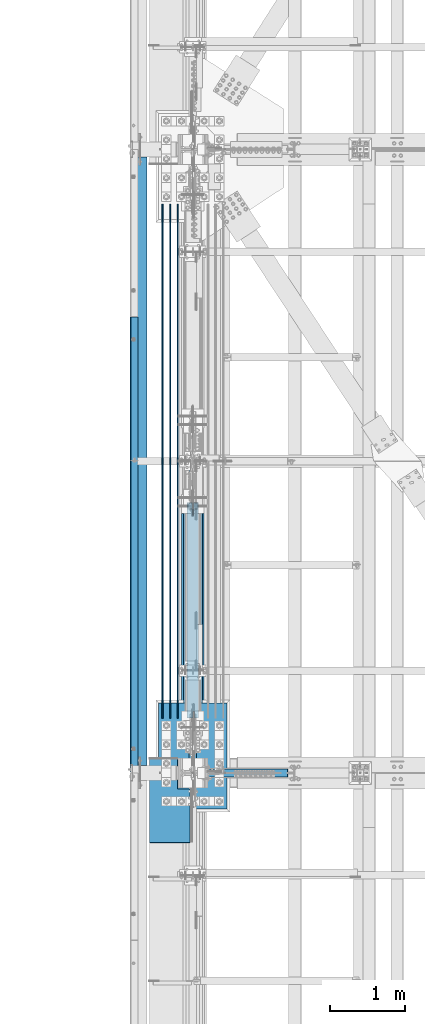
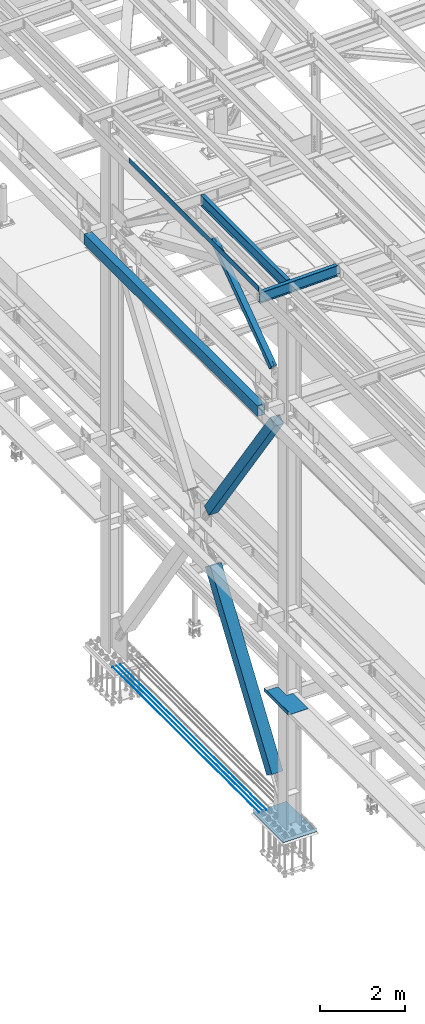
# One storey, part 1867 of 3843: 9 beams, 3 members, 12 elements without a shape of their own.
"""IFC2X3 building model written with IfcOpenShell, lengths in millimetres."""

from ifc_helpers import new_model, si_unit, frame, origin_with_axes, place, context, subcontext, project, spatial, faceted_brep, material, type_object, element, aggregate, save


model = new_model("IFC2X3")

# Units and contexts
model_context = context("Model", 3, precision=1e-05, world=origin_with_axes())
body_context = subcontext(model_context, "Body", "Model", "MODEL_VIEW")
ifc_project = project(units=[si_unit("LENGTHUNIT", "METRE", prefix="MILLI"), si_unit("AREAUNIT", "SQUARE_METRE"), si_unit("VOLUMEUNIT", "CUBIC_METRE"), si_unit("MASSUNIT", "GRAM", prefix="KILO"), si_unit("TIMEUNIT", "SECOND"), si_unit("PLANEANGLEUNIT", "RADIAN"), si_unit("SOLIDANGLEUNIT", "STERADIAN"), si_unit("THERMODYNAMICTEMPERATUREUNIT", "DEGREE_CELSIUS"), si_unit("LUMINOUSINTENSITYUNIT", "LUMEN")], contexts=[model_context])

# Site, building, storey
site_placement = place(None, origin_with_axes())
site = spatial("IfcSite", under=ifc_project, at=site_placement, CompositionType="ELEMENT")
building_placement = place(site_placement, origin_with_axes())
building = spatial("IfcBuilding", under=site, at=building_placement, Name="Undefined", CompositionType="ELEMENT")
storey_placement = place(building_placement, origin_with_axes())
storey = spatial("IfcBuildingStorey", under=building, at=storey_placement, Name="Undefined", CompositionType="ELEMENT", Elevation=0.0)

# Assembly, beam
assembly_1_placement = place(storey_placement, origin_with_axes())
assembly_1 = element("IfcElementAssembly", 1, at=assembly_1_placement, inside=storey, Name="REBAR", AssemblyPlace="NOTDEFINED", PredefinedType="RIGID_FRAME")
ifc_material_1 = material(Name="STEEL/A706-60")
beam_type_1 = type_object("IfcBeamType", Name="#10 REBAR", PredefinedType="NOTDEFINED")
beam_1_placement = place(assembly_1_placement, frame((36169.6000610352, 68008.5000170885, 30170.4375), z_axis=(0.0, 0.0, 1.0), x_axis=(0.0, 1.0, 0.0)))
beam_1 = element("IfcBeam", 2, at=beam_1_placement, type_object=beam_type_1, material=ifc_material_1, Name="REBAR", ObjectType="#10 REBAR", context=body_context, shape_type="Brep", body=[
    faceted_brep([(0.0, -7.9375, 0.0), (0.0, -5.61266007566883, -5.61266007566883), (6883.48749999408, -5.61266007566883, -5.61266007566883), (6883.48749999408, -7.9375, 0.0), (0.0, 0.0, -7.9375), (6883.48749999408, 0.0, -7.9375), (0.0, 5.61266007566883, -5.61266007566883), (6883.48749999408, 5.61266007566883, -5.61266007566883), (0.0, 7.9375, 0.0), (6883.48749999408, 7.9375, 0.0), (0.0, 5.61266007566883, 5.61266007566883), (6883.48749999408, 5.61266007566883, 5.61266007566883), (0.0, 0.0, 7.9375), (6883.48749999408, 0.0, 7.9375), (0.0, -5.61266007566883, 5.61266007566883), (6883.48749999408, -5.61266007566883, 5.61266007566883)], [[[0, 1, 2, 3]], [[1, 4, 5, 2]], [[4, 6, 7, 5]], [[6, 8, 9, 7]], [[8, 10, 11, 9]], [[10, 12, 13, 11]], [[12, 14, 15, 13]], [[14, 0, 3, 15]], [[5, 7, 9, 11, 13, 15, 3, 2]], [[14, 12, 10, 8, 6, 4, 1, 0]]]),
])
aggregate(assembly_1, [beam_1])

assembly_2_placement = place(storey_placement, origin_with_axes())
assembly_2 = element("IfcElementAssembly", 3, at=assembly_2_placement, inside=storey, Name="REBAR", AssemblyPlace="NOTDEFINED", PredefinedType="RIGID_FRAME")
beam_2_placement = place(assembly_2_placement, frame((36271.2000610352, 68008.5000170885, 30170.4375), z_axis=(0.0, 0.0, 1.0), x_axis=(0.0, 1.0, 0.0)))
beam_2 = element("IfcBeam", 4, at=beam_2_placement, type_object=beam_type_1, material=ifc_material_1, Name="REBAR", ObjectType="#10 REBAR", context=body_context, shape_type="Brep", body=[
    faceted_brep([(0.0, -7.9375, 0.0), (0.0, -5.61266007566883, -5.61266007566883), (6883.48749999408, -5.61266007566883, -5.61266007566883), (6883.48749999408, -7.9375, 0.0), (0.0, 0.0, -7.9375), (6883.48749999408, 0.0, -7.9375), (0.0, 5.61266007566883, -5.61266007566883), (6883.48749999408, 5.61266007566883, -5.61266007566883), (0.0, 7.9375, 0.0), (6883.48749999408, 7.9375, 0.0), (0.0, 5.61266007566883, 5.61266007566883), (6883.48749999408, 5.61266007566883, 5.61266007566883), (0.0, 0.0, 7.9375), (6883.48749999408, 0.0, 7.9375), (0.0, -5.61266007566883, 5.61266007566883), (6883.48749999408, -5.61266007566883, 5.61266007566883)], [[[0, 1, 2, 3]], [[1, 4, 5, 2]], [[4, 6, 7, 5]], [[6, 8, 9, 7]], [[8, 10, 11, 9]], [[10, 12, 13, 11]], [[12, 14, 15, 13]], [[14, 0, 3, 15]], [[5, 7, 9, 11, 13, 15, 3, 2]], [[14, 12, 10, 8, 6, 4, 1, 0]]]),
])
aggregate(assembly_2, [beam_2])

assembly_3_placement = place(storey_placement, origin_with_axes())
assembly_3 = element("IfcElementAssembly", 5, at=assembly_3_placement, inside=storey, Name="REBAR", AssemblyPlace="NOTDEFINED", PredefinedType="RIGID_FRAME")
beam_3_placement = place(assembly_3_placement, frame((36372.8000610352, 68008.5000170885, 30170.4375), z_axis=(0.0, 0.0, 1.0), x_axis=(0.0, 1.0, 0.0)))
beam_3 = element("IfcBeam", 6, at=beam_3_placement, type_object=beam_type_1, material=ifc_material_1, Name="REBAR", ObjectType="#10 REBAR", context=body_context, shape_type="Brep", body=[
    faceted_brep([(0.0, -7.9375, 0.0), (0.0, -5.61266007566883, -5.61266007566883), (6883.48749999408, -5.61266007566883, -5.61266007566883), (6883.48749999408, -7.9375, 0.0), (0.0, 0.0, -7.9375), (6883.48749999408, 0.0, -7.9375), (0.0, 5.61266007566883, -5.61266007566883), (6883.48749999408, 5.61266007566883, -5.61266007566883), (0.0, 7.9375, 0.0), (6883.48749999408, 7.9375, 0.0), (0.0, 5.61266007566883, 5.61266007566883), (6883.48749999408, 5.61266007566883, 5.61266007566883), (0.0, 0.0, 7.9375), (6883.48749999408, 0.0, 7.9375), (0.0, -5.61266007566883, 5.61266007566883), (6883.48749999408, -5.61266007566883, 5.61266007566883)], [[[0, 1, 2, 3]], [[1, 4, 5, 2]], [[4, 6, 7, 5]], [[6, 8, 9, 7]], [[8, 10, 11, 9]], [[10, 12, 13, 11]], [[12, 14, 15, 13]], [[14, 0, 3, 15]], [[5, 7, 9, 11, 13, 15, 3, 2]], [[14, 12, 10, 8, 6, 4, 1, 0]]]),
])
aggregate(assembly_3, [beam_3])

assembly_4_placement = place(storey_placement, origin_with_axes())
assembly_4 = element("IfcElementAssembly", 7, at=assembly_4_placement, inside=storey, Name="BEAM", AssemblyPlace="NOTDEFINED", PredefinedType="RIGID_FRAME")
ifc_material_2 = material(Name="STEEL/A36")
beam_type_2 = type_object("IfcBeamType", PredefinedType="NOTDEFINED")
beam_4_placement = place(assembly_4_placement, frame((35839.3101110323, 70335.775, 45717.1843160678), z_axis=(0.0, -1.0, 0.0), x_axis=(-0.999776270257024, 0.0, -0.0211520550054595)))
beam_4 = element("IfcBeam", 8, at=beam_4_placement, type_object=beam_type_2, material=ifc_material_2, Name="BENT_PLATE", context=body_context, shape_type="Brep", body=[
    faceted_brep([(-3.50355549016967e-07, -3.17499999742722, -3048.00000001723), (3.50421032635495e-07, -3.17500000260043, 3048.00000001724), (3.5035191103816e-07, 3.17499999739084, 3048.00000001724), (-3.50424670614302e-07, 3.17500000256405, -3048.00000001723), (101.599999864371, 3.17499999856227, 3048.00000000522), (101.599998739839, 3.17500000373548, -3048.00000002925), (95.249998765099, -3.17499999632128, -3048.00000002851), (95.2499998896274, -3.17500000149448, 3048.00000000597), (101.600000309205, -161.925000875126, 3047.9999999938), (101.599999608374, -161.925000446165, -3048.00000004067), (95.2500003092064, -161.925000900388, 3047.99999999456), (95.2499996083752, -161.925000471427, -3048.00000003992)], [[[0, 1, 2, 3]], [[3, 2, 4, 5]], [[1, 0, 6, 7]], [[5, 4, 8, 9]], [[4, 2, 1, 7, 10, 8]], [[7, 6, 11, 10]], [[6, 0, 3, 5, 9, 11]], [[10, 11, 9, 8]]]),
])
aggregate(assembly_4, [beam_4])

assembly_5_placement = place(storey_placement, origin_with_axes())
assembly_5 = element("IfcElementAssembly", 9, at=assembly_5_placement, inside=storey, Name="GIRT", AssemblyPlace="NOTDEFINED", PredefinedType="RIGID_FRAME")
ifc_material_3 = material()
beam_type_3 = type_object("IfcBeamType", Name="HSS12X8X3/8", PredefinedType="NOTDEFINED")
beam_5_placement = place(assembly_5_placement, frame((35861.625, 67271.9, 42214.8), z_axis=(0.0, 0.0, 1.0), x_axis=(0.0, 1.0, 0.0)))
beam_5 = element("IfcBeam", 10, at=beam_5_placement, type_object=beam_type_3, material=ifc_material_3, Name="GIRT", ObjectType="HSS12X8X3/8", context=body_context, shape_type="Brep", body=[
    faceted_brep([(8253.41249999999, 101.599999999999, -152.400000000001), (8253.41249999999, -101.599999999999, -152.400000000001), (103.1875, -101.600000000006, -152.400000000001), (103.1875, 101.600000000006, -152.400000000001), (8253.41249999999, 101.599999999999, 152.400000000001), (103.1875, 101.600000000006, 152.400000000001), (8253.41249999999, -101.599999999999, 152.400000000001), (103.1875, -101.600000000006, 152.400000000001), (8253.41249999999, 92.0749999999971, -142.875), (8253.41249999999, -92.0749999999971, -142.875), (8253.41249999999, -92.0749999999971, 142.875), (8253.41249999999, 92.0749999999971, 142.875), (103.1875, -92.0749999999971, 142.875), (103.1875, 92.0749999999971, 142.875), (103.1875, 92.0749999999971, -142.875), (103.1875, -92.0749999999971, -142.875)], [[[0, 1, 2, 3]], [[4, 0, 3, 5]], [[6, 4, 5, 7]], [[1, 6, 7, 2]], [[0, 4, 6, 1], [8, 9, 10, 11]], [[11, 10, 12, 13]], [[8, 11, 13, 14]], [[9, 8, 14, 15]], [[10, 9, 15, 12]], [[3, 2, 7, 5], [14, 13, 12, 15]]]),
])
aggregate(assembly_5, [beam_5])

assembly_6_placement = place(storey_placement, origin_with_axes())
assembly_6 = element("IfcElementAssembly", 11, at=assembly_6_placement, inside=storey, Name="BEAM", AssemblyPlace="NOTDEFINED", PredefinedType="RIGID_FRAME")
ifc_material_4 = material(Name="STEEL/A992")
beam_type_4 = type_object("IfcBeamType", Name="W12X19", PredefinedType="NOTDEFINED")
beam_6_placement = place(assembly_6_placement, frame((36575.9999999767, 67271.9, 45575.6071293692), z_axis=(0.0, 0.0, 1.0), x_axis=(0.0, 1.0, 0.0)))
beam_6 = element("IfcBeam", 12, at=beam_6_placement, type_object=beam_type_4, material=ifc_material_4, Name="BEAM", ObjectType="W12X19", context=body_context, shape_type="Brep", body=[
    faceted_brep([(15.8750000000146, -3.17500000000291, -128.587499998961), (15.8750000000146, 3.17500000000291, -128.587499998961), (53.9750001907523, 3.17500000000291, -128.587499998961), (53.9750001907523, -3.17500000000291, -128.587499998961), (58.8350797087915, 3.17500000000291, -129.554229921552), (58.8350797087915, -3.17500000000291, -129.554229921552), (62.9552561769524, 3.17500000000291, -132.307243822026), (62.9552561769524, -3.17500000000291, -132.307243822026), (65.7082700774336, 3.17500000000291, -136.42742029018), (65.7082700774336, -3.17500000000291, -136.42742029018), (66.6750000000175, -3.17500000000291, -141.287499808226), (66.6750000000175, 3.17500000000291, -141.287499808226), (66.6750000000175, 3.17500000000291, -144.462500000001), (66.6750000000175, 50.8000000000029, -144.462500000001), (66.6750000000175, 50.8000000000029, -153.987500000003), (66.6750000000029, -50.8000000000029, -154.061789990948), (66.6750000000175, -50.8000000000029, -144.462500000001), (66.6750000000175, -3.17500000000291, -144.462500000001), (4111.62499999991, 50.8000000000029, 144.462500000001), (4111.62499999991, 3.17500000000291, 144.462500000001), (66.6750000000175, 3.17500000000291, 144.462500000001), (66.6750000000175, 50.8000000000029, 144.462500000001), (53.9750001907523, -3.17500000000291, 128.587500001042), (53.9750001907523, 3.17500000000291, 128.587500001042), (15.8750000000146, 3.17500000000291, 128.587500001042), (15.8750000000146, -3.17500000000291, 128.587500001042), (58.8350797087915, -3.17500000000291, 129.554229923633), (58.8350797087915, 3.17500000000291, 129.554229923633), (62.9552561769524, -3.17500000000291, 132.307243824107), (62.9552561769524, 3.17500000000291, 132.307243824107), (65.7082700774336, -3.17500000000291, 136.427420292261), (65.7082700774336, 3.17500000000291, 136.427420292261), (66.6750000000175, -3.17500000000291, 141.287499810307), (66.6750000000175, 3.17500000000291, 141.287499810307), (4111.62499999991, -50.8000000000029, 153.987500000003), (4111.62499999991, 50.8000000000029, 153.987500000003), (66.6750000000175, 50.8000000000029, 153.987500000003), (66.6750000000029, -50.8000000000029, 154.149069844731), (4111.62499999991, -50.8000000000029, 144.462500000001), (66.6750000000175, -50.8000000000029, 144.462500000001), (4111.62499999991, -3.17500000000291, 144.462500000001), (66.6750000000175, -3.17500000000291, 144.462500000001), (4111.62499999991, -3.17500000000291, 141.287499810329), (4111.62499999991, 3.17500000000291, 141.287499810329), (4112.5917299225, -3.17500000000291, 136.427420292282), (4112.5917299225, 3.17500000000291, 136.427420292282), (4115.34474382298, -3.17500000000291, 132.307243824129), (4115.34474382298, 3.17500000000291, 132.307243824129), (4119.46492029114, -3.17500000000291, 129.554229923655), (4119.46492029114, 3.17500000000291, 129.554229923655), (4124.32499980918, -3.17500000000291, 128.587500001064), (4124.32499980918, 3.17500000000291, 128.587500001064), (4162.42499999992, -3.17500000000291, 128.587500001064), (4162.42499999992, 3.17500000000291, 128.587500001064), (4162.42499999992, 3.17500000000291, -114.712499998423), (4162.42499999992, 3.17500000000291, 115.887500001576), (4162.42499999992, -3.17500000000291, -128.587499998939), (4162.42499999992, 3.17500000000291, -128.587499998939), (4124.32499980918, -3.17500000000291, -128.587499998939), (4124.32499980918, 3.17500000000291, -128.587499998939), (4119.46492029114, -3.17500000000291, -129.55422992153), (4119.46492029114, 3.17500000000291, -129.55422992153), (4115.34474382298, -3.17500000000291, -132.307243822004), (4115.34474382298, 3.17500000000291, -132.307243822004), (4112.5917299225, -3.17500000000291, -136.427420290158), (4112.5917299225, 3.17500000000291, -136.427420290158), (4111.62499999991, -3.17500000000291, -141.287499808204), (4111.62499999991, 3.17500000000291, -141.287499808204), (4111.62499999991, -3.17500000000291, -144.462500000001), (4111.62499999991, -50.8000000000029, -144.462500000001), (4111.62499999991, -50.8000000000029, -153.987500000003), (4111.62499999991, 50.8000000000029, -153.987500000003), (4111.62499999991, 50.8000000000029, -144.462500000001), (4111.62499999991, 3.17500000000291, -144.462500000001), (15.8750000000146, 3.17500000000291, -114.712499998386), (15.8750000000146, 3.17500000000291, 115.887500001612)], [[[0, 1, 2, 3]], [[3, 2, 4, 5]], [[5, 4, 6, 7]], [[7, 6, 8, 9]], [[10, 11, 12, 13, 14, 15, 16, 17]], [[9, 8, 11, 10]], [[18, 19, 20, 21]], [[22, 23, 24, 25]], [[26, 27, 23, 22]], [[28, 29, 27, 26]], [[30, 31, 29, 28]], [[32, 33, 31, 30]], [[34, 35, 36, 37]], [[38, 34, 37, 39]], [[40, 38, 39, 41]], [[37, 36, 21, 20, 33, 32, 41, 39]], [[35, 18, 21, 36]], [[34, 38, 40, 42, 43, 19, 18, 35]], [[44, 45, 43, 42]], [[46, 47, 45, 44]], [[48, 49, 47, 46]], [[50, 51, 49, 48]], [[52, 53, 51, 50]], [[54, 55, 53, 52, 56, 57]], [[56, 58, 59, 57]], [[60, 61, 59, 58]], [[62, 63, 61, 60]], [[64, 65, 63, 62]], [[66, 67, 65, 64]], [[68, 69, 70, 71, 72, 73, 67, 66]], [[69, 68, 17, 16]], [[70, 69, 16, 15]], [[71, 70, 15, 14]], [[72, 71, 14, 13]], [[73, 72, 13, 12]], [[6, 4, 2, 1, 74, 75, 24, 23, 27, 29, 31, 33, 20, 19, 43, 45, 47, 49, 51, 53, 55, 54, 57, 59, 61, 63, 65, 67, 73, 12, 11, 8]], [[25, 24, 75, 74, 1, 0]], [[68, 66, 64, 62, 60, 58, 56, 52, 50, 48, 46, 44, 42, 40, 41, 32, 30, 28, 26, 22, 25, 0, 3, 5, 7, 9, 10, 17]]]),
])
aggregate(assembly_6, [beam_6])

assembly_7_placement = place(storey_placement, origin_with_axes())
assembly_7 = element("IfcElementAssembly", 13, at=assembly_7_placement, inside=storey, Name="BEAM", AssemblyPlace="NOTDEFINED", PredefinedType="RIGID_FRAME")
beam_7_placement = place(assembly_7_placement, frame((35741.6287365059, 67271.9, 45557.9210793685), z_axis=(-0.024863995002168, 0.0, 0.999690843087268), x_axis=(0.999690843087268, 0.0, 0.0248639950021699)))
beam_7 = element("IfcBeam", 14, at=beam_7_placement, type_object=beam_type_4, material=ifc_material_4, Name="BEAM", ObjectType="W12X19", context=body_context, shape_type="Brep", body=[
    faceted_brep([(2104.36612032058, -3.17500000000291, -144.462500002875), (2104.36612032058, -50.8000000000029, -144.462500002875), (2104.33075495699, -50.8000000000029, -153.987500002848), (2104.33075495699, 50.8000000000029, -153.987500002848), (2104.36612032058, 50.8000000000029, -144.462500002875), (2104.36612032058, 3.17500000000291, -144.462500002875), (2104.37924137199, 3.17500000000291, -140.920293993498), (2104.37924137199, -3.17500000000291, -140.920293993498), (2105.36400924376, 3.17500000000291, -136.063837270354), (2105.36400924376, -3.17500000000291, -136.063837270354), (2108.1323016527, 3.17500000000291, -131.95391065257), (2108.1323016527, -3.17500000000291, -131.95391065257), (2112.26267117421, 3.17500000000291, -129.216213211119), (2112.26267117421, -3.17500000000291, -129.216213211119), (2117.1263064905, 3.17500000000291, -128.267534564176), (2117.1263064905, -3.17500000000291, -128.267534564176), (2186.97582521871, -3.17500000000291, -128.526875213989), (2186.97582521871, 3.17500000000291, -128.526875213989), (4.36557456851006e-11, 3.17500000000291, 144.462499999994), (4.36557456851006e-11, 50.8000000000029, 144.462499999994), (2105.43886968171, 50.8000000000029, 144.462499996145), (2105.43886968171, 3.17500000000291, 144.462499996145), (-3.63797880709171e-11, -50.8000000000029, -153.987499999988), (-3.63797880709171e-11, -50.8000000000029, -144.46249999998), (-3.63797880709171e-11, -3.17500000000291, -144.46249999998), (4.36557456851006e-11, -3.17500000000291, 144.462499999994), (4.36557456851006e-11, -50.8000000000029, 144.462499999994), (3.63797880709171e-11, -50.8000000000029, 153.987499999988), (3.63797880709171e-11, 50.8000000000029, 153.987499999988), (-3.63797880709171e-11, 3.17500000000291, -144.46249999998), (-3.63797880709171e-11, 50.8000000000029, -144.46249999998), (-3.63797880709171e-11, 50.8000000000029, -153.987499999988), (2105.43886968171, -3.17500000000291, 144.462499996145), (2105.43886968171, -50.8000000000029, 144.462499996145), (2105.47423504531, -50.8000000000029, 153.987499996125), (2105.47423504531, 50.8000000000029, 153.987499996125), (2105.42839217778, -3.17500000000291, 141.652757960757), (2105.42839217778, 3.17500000000291, 141.652757960757), (2106.37707082472, -3.17500000000291, 136.78912264447), (2106.37707082472, 3.17500000000291, 136.78912264447), (2109.11476826618, -3.17500000000291, 132.658753122974), (2109.11476826618, 3.17500000000291, 132.658753122974), (2113.22469488396, -3.17500000000291, 129.890460714036), (2113.22469488396, 3.17500000000291, 129.890460714036), (2118.0811516071, -3.17500000000291, 128.905692842258), (2118.0811516071, 3.17500000000291, 128.905692842258), (2187.93067033629, -3.17500000000291, 128.646352192452), (2187.93067033629, 3.17500000000291, 128.646352192452)], [[[0, 1, 2, 3, 4, 5, 6, 7]], [[7, 6, 8, 9]], [[9, 8, 10, 11]], [[11, 10, 12, 13]], [[13, 12, 14, 15]], [[16, 15, 14, 17]], [[18, 19, 20, 21]], [[22, 23, 24, 25, 26, 27, 28, 19, 18, 29, 30, 31]], [[26, 25, 32, 33]], [[27, 26, 33, 34]], [[28, 27, 34, 35]], [[19, 28, 35, 20]], [[34, 33, 32, 36, 37, 21, 20, 35]], [[38, 39, 37, 36]], [[40, 41, 39, 38]], [[42, 43, 41, 40]], [[44, 45, 43, 42]], [[46, 47, 45, 44]], [[47, 46, 16, 17]], [[12, 10, 8, 6, 5, 29, 18, 21, 37, 39, 41, 43, 45, 47, 17, 14]], [[30, 29, 5, 4]], [[31, 30, 4, 3]], [[22, 31, 3, 2]], [[23, 22, 2, 1]], [[24, 23, 1, 0]], [[46, 44, 42, 40, 38, 36, 32, 25, 24, 0, 7, 9, 11, 13, 15, 16]]]),
])
aggregate(assembly_7, [beam_7])

# Assembly, member
assembly_8_placement = place(storey_placement, origin_with_axes())
assembly_8 = element("IfcElementAssembly", 15, at=assembly_8_placement, inside=storey, Name="None", AssemblyPlace="NOTDEFINED", PredefinedType="RIGID_FRAME")
member_type_1 = type_object("IfcMemberType", Name="HSS10X10X1/4", PredefinedType="NOTDEFINED")
member_1_placement = place(assembly_8_placement, frame((36576.0, 70968.305413608, 36941.8524738539), z_axis=(-1.0, 0.0, 0.0), x_axis=(0.0, -0.572746499261054, 0.819732546373637)))
member_1 = element("IfcMember", 16, at=member_1_placement, type_object=member_type_1, material=ifc_material_4, Name="None", ObjectType="HSS10X10X1/4", context=body_context, shape_type="Brep", body=[
    faceted_brep([(2.00088834390044e-10, 120.650000000089, -120.649999999994), (-2.03726813197136e-10, -120.650000000081, -120.649999999994), (5403.85000024675, -120.650000015012, -120.650000000001), (5403.85000024701, 120.649999984038, -120.650000000001), (-2.03726813197136e-10, -120.650000000081, 120.649999999994), (5403.85000024675, -120.650000015012, 120.650000000001), (2.00088834390044e-10, 120.650000000089, 120.649999999994), (5403.85000024701, 120.649999984038, 120.650000000001), (2.16459739021957e-10, 127.000000000087, -127.0), (2.16459739021957e-10, 127.000000000087, 127.0), (5403.85000024701, 126.999999984007, 127.0), (5403.85000024701, 126.999999984007, -127.0), (-2.14640749618411e-10, -127.00000000008, 127.0), (5403.85000024675, -127.000000014988, 127.0), (-2.14640749618411e-10, -127.00000000008, -127.0), (5403.85000024675, -127.000000014988, -127.0)], [[[0, 1, 2, 3]], [[1, 4, 5, 2]], [[4, 6, 7, 5]], [[6, 0, 3, 7]], [[8, 9, 10, 11]], [[9, 12, 13, 10]], [[12, 14, 15, 13]], [[14, 8, 11, 15]], [[13, 15, 11, 10], [5, 7, 3, 2]], [[14, 12, 9, 8], [6, 4, 1, 0]]]),
])
aggregate(assembly_8, [member_1])

assembly_9_placement = place(storey_placement, origin_with_axes())
assembly_9 = element("IfcElementAssembly", 17, at=assembly_9_placement, inside=storey, Name="None", AssemblyPlace="NOTDEFINED", PredefinedType="RIGID_FRAME")
member_type_2 = type_object("IfcMemberType", Name="HSS12X12X5/16", PredefinedType="NOTDEFINED")
member_2_placement = place(assembly_9_placement, frame((36575.9999938965, 67974.2514474577, 31186.1398761761), z_axis=(1.0, 0.0, 0.0), x_axis=(0.0, 0.5657622650086, 0.824568408012542)))
member_2 = element("IfcMember", 18, at=member_2_placement, type_object=member_type_2, material=ifc_material_4, Name="None", ObjectType="HSS12X12X5/16", context=body_context, shape_type="Brep", body=[
    faceted_brep([(-2.61934474110603e-10, 144.462500000002, -144.462500000001), (2.61934474110603e-10, -144.462499999993, -144.462500000001), (5124.45041186737, -144.462499974092, -144.462500000001), (5124.45041186616, 144.462500026799, -144.462500000001), (2.61934474110603e-10, -144.462499999993, 144.462500000001), (5124.45041186737, -144.462499974092, 144.462500000001), (-2.61934474110603e-10, 144.462500000002, 144.462500000001), (5124.45041186616, 144.462500026799, 144.462500000001), (-2.7648638933897e-10, 152.400000000002, -152.400000000001), (-2.7648638933897e-10, 152.400000000002, 152.400000000001), (5124.45041186612, 152.400000026828, 152.400000000001), (5124.45041186612, 152.400000026828, -152.400000000001), (2.83762346953154e-10, -152.399999999993, 152.400000000001), (5124.4504118674, -152.399999974121, 152.400000000001), (2.83762346953154e-10, -152.399999999993, -152.400000000001), (5124.4504118674, -152.399999974121, -152.400000000001)], [[[0, 1, 2, 3]], [[1, 4, 5, 2]], [[4, 6, 7, 5]], [[6, 0, 3, 7]], [[8, 9, 10, 11]], [[9, 12, 13, 10]], [[12, 14, 15, 13]], [[14, 8, 11, 15]], [[13, 15, 11, 10], [5, 7, 3, 2]], [[14, 12, 9, 8], [6, 4, 1, 0]]]),
])
aggregate(assembly_9, [member_2])

# Assembly, beam
assembly_10_placement = place(storey_placement, origin_with_axes())
assembly_10 = element("IfcElementAssembly", 19, at=assembly_10_placement, inside=storey, Name="BEAM", AssemblyPlace="NOTDEFINED", PredefinedType="RIGID_FRAME")
beam_type_5 = type_object("IfcBeamType", PredefinedType="NOTDEFINED")
beam_8_placement = place(assembly_10_placement, frame((36537.9, 66903.6, 34039.175), z_axis=(0.0, -1.0, 0.0), x_axis=(-1.0, 0.0, 0.0)))
beam_8 = element("IfcBeam", 20, at=beam_8_placement, type_object=beam_type_5, material=ifc_material_2, Name="BENT_PLATE", context=body_context, shape_type="Brep", body=[
    faceted_brep([(539.750000000029, -3.17500000000291, 565.15000004771), (542.924999952309, -4.77084540762007e-08, 568.324999999997), (0.0, -4.77084540762007e-08, 568.324999999997), (0.0, -3.17500000000291, 565.15000004771), (539.750000000029, -98.4249999999665, 565.15000004771), (542.924999952309, -98.4249999999665, 568.324999999997), (0.0, -3.17500000000291, -155.575000000026), (168.275000000031, -3.17500000000291, -155.575000000026), (168.275000000031, -3.17500000000291, -568.324999999997), (539.750000000029, -3.17500000000291, -568.324999999997), (168.275000000031, 3.17500000000291, -155.575000000026), (168.275000000031, 3.17500000000291, -568.324999999997), (0.0, 3.17500000000291, -155.575000000026), (546.100000000035, -98.4249999999665, 568.324999999997), (546.100000000035, 3.17500000000291, 568.324999999997), (0.0, 3.17500000000291, 568.324999999997), (546.100000000035, 3.17500000000291, -568.324999999997), (546.100000000035, -98.4249999999665, -568.324999999997), (539.750000000029, -98.4249999999665, -568.324999999997)], [[[0, 1, 2, 3]], [[4, 5, 1, 0]], [[6, 7, 8, 9, 0, 3]], [[7, 10, 11, 8]], [[6, 12, 10, 7]], [[5, 13, 14, 15, 2, 1]], [[16, 14, 13, 17]], [[18, 17, 13, 5, 4]], [[9, 18, 4, 0]], [[16, 17, 18, 9, 8, 11]], [[15, 14, 16, 11, 10, 12]], [[15, 12, 6, 3, 2]]]),
])
aggregate(assembly_10, [beam_8])

# Assembly, member
assembly_11_placement = place(storey_placement, origin_with_axes())
assembly_11 = element("IfcElementAssembly", 21, at=assembly_11_placement, inside=storey, AssemblyPlace="NOTDEFINED", PredefinedType="RIGID_FRAME")
member_type_3 = type_object("IfcMemberType", Name="HSS6X6X3/8", PredefinedType="NOTDEFINED")
member_3_placement = place(assembly_11_placement, frame((36576.0000000077, 67271.9, 42232.2625), z_axis=(1.0, 0.0, 0.0), x_axis=(0.0, 0.814318393718904, 0.580418429799627)))
member_3 = element("IfcMember", 22, at=member_3_placement, type_object=member_type_3, material=ifc_material_3, ObjectType="HSS6X6X3/8", context=body_context, shape_type="Brep", body=[
    faceted_brep([(4395.93732697911, -76.1999999929685, -7.93750007607741), (4395.9373269791, -66.6749999929307, -7.93750007607741), (4295.92482697344, -66.6749999931053, -7.93750007607741), (4295.92482697347, -76.1999999931431, -7.93750007607741), (4292.88727722902, -66.6749999931126, -7.33329386538389), (4292.88727722902, -76.1999999931431, -7.33329386538389), (4290.31216689771, -66.6749999931199, -5.61266015174624), (4290.31216689774, -76.1999999931504, -5.61266015174624), (4288.59153318405, -66.6749999931126, -3.03754982047394), (4288.59153318408, -76.1999999931504, -3.03754982047394), (4287.98732697335, -66.6749999931126, -7.60774128139019e-08), (4287.98732697338, -76.1999999931577, -7.60774128139019e-08), (4288.59153318405, -66.6749999931126, 3.03754966831912), (4288.59153318408, -76.1999999931504, 3.03754966831912), (4290.31216689771, -66.6749999931199, 5.61265999959141), (4290.31216689774, -76.1999999931504, 5.61265999959141), (4292.88727722902, -66.6749999931126, 7.33329371322907), (4292.88727722902, -76.1999999931431, 7.33329371322907), (4295.92482697344, -66.6749999931053, 7.93749992392259), (4295.92482697347, -76.1999999931431, 7.93749992392259), (4395.93732697911, -76.1999999929685, 7.93749992392259), (4395.9373269791, -66.6749999929307, 7.93749992392259), (4395.9373269791, 66.6750000075481, -7.93750007607741), (4395.93732697911, 76.2000000075786, -7.93750007607741), (4295.92482697321, 76.2000000074113, -7.93750007607741), (4295.92482697323, 66.6750000073807, -7.93750007607741), (4292.88727722879, 76.2000000074113, -7.33329386538389), (4292.88727722879, 66.6750000073735, -7.33329386538389), (4290.31216689748, 76.200000007404, -5.61266015174624), (4290.31216689749, 66.6750000073662, -5.61266015174624), (4288.59153318382, 76.2000000073967, -3.03754982047394), (4288.59153318385, 66.6750000073662, -3.03754982047394), (4287.98732697312, 76.200000007404, -7.60774128139019e-08), (4287.98732697313, 66.6750000073662, -7.60774128139019e-08), (4288.59153318382, 76.2000000073967, 3.03754966831912), (4288.59153318385, 66.6750000073662, 3.03754966831912), (4290.31216689748, 76.200000007404, 5.61265999959141), (4290.31216689749, 66.6750000073662, 5.61265999959141), (4292.88727722879, 76.2000000074113, 7.33329371322907), (4292.88727722879, 66.6750000073735, 7.33329371322907), (4295.92482697321, 76.2000000074113, 7.93749992392259), (4295.92482697323, 66.6750000073807, 7.93749992392259), (4395.9373269791, 66.6750000075481, 7.93749992392259), (4395.93732697911, 76.2000000075786, 7.93749992392259), (959.380217961443, -66.6749999986496, 66.6750000000029), (959.380217961443, 66.6750000018365, 66.6750000000029), (4395.9373269791, 66.6750000075481, 66.6750000000029), (4395.9373269791, -66.6749999929307, 66.6750000000029), (4395.9373269791, -66.6749999929307, -66.6750000000029), (959.380217961443, -66.6749999986496, -66.6750000000029), (959.380217961443, -66.6749999986496, 4.76249999999709), (1059.39271796733, -66.6749999984822, 4.76249999999709), (1062.43026771175, -66.674999998475, 5.36670621069061), (1065.00537804306, -66.6749999984822, 7.08733992432826), (1066.72601175672, -66.6749999984677, 9.66245025560056), (1067.33021796742, -66.6749999984677, 12.6999999999971), (1066.72601175672, -66.6749999984677, 15.7375497443936), (1065.00537804306, -66.6749999984822, 18.3126600756659), (1062.43026771175, -66.674999998475, 20.0332937893036), (1059.39271796733, -66.6749999984822, 20.6374999999971), (959.380217961443, -66.6749999986496, 20.6374999999971), (959.380217961443, 66.6750000018365, -66.6750000000029), (4395.9373269791, 66.6750000075481, -66.6750000000029), (959.380217961443, 66.6750000018365, 20.6374999999971), (959.380217961443, 76.200000001867, 20.6374999999971), (1059.39271796709, 76.2000000020416, 20.6374999999971), (1059.3927179671, 66.6750000019965, 20.6374999999971), (1062.43026771152, 76.2000000020489, 20.0332937893036), (1062.43026771153, 66.6750000020038, 20.0332937893036), (1065.00537804283, 76.2000000020489, 18.3126600756659), (1065.00537804284, 66.6750000020111, 18.3126600756659), (1066.72601175649, 76.2000000020489, 15.7375497443936), (1066.7260117565, 66.6750000020111, 15.7375497443936), (1067.33021796719, 76.2000000020562, 12.6999999999971), (1067.33021796719, 66.6750000020184, 12.6999999999971), (1066.72601175649, 76.2000000020489, 9.66245025560056), (1066.7260117565, 66.6750000020111, 9.66245025560056), (1065.00537804283, 76.2000000020489, 7.08733992432826), (1065.00537804284, 66.6750000020111, 7.08733992432826), (1062.43026771152, 76.2000000020489, 5.36670621069061), (1062.43026771153, 66.6750000020038, 5.36670621069061), (1059.39271796709, 76.2000000020416, 4.76249999999709), (1059.3927179671, 66.6750000019965, 4.76249999999709), (959.380217961443, 76.200000001867, 4.76249999999709), (959.380217961443, 66.6750000018365, 4.76249999999709), (959.380217961443, 76.200000001867, -76.1999999999971), (959.380217961443, -76.1999999986874, -76.1999999999971), (959.380217961443, -76.1999999986874, 4.76249999999709), (1059.39271796735, -76.1999999985128, 4.76249999999709), (1062.43026771178, -76.1999999985128, 5.36670621069061), (1065.00537804308, -76.1999999985128, 7.08733992432826), (1066.72601175675, -76.1999999985055, 9.66245025560056), (1067.33021796742, -76.1999999984982, 12.6999999999971), (1066.72601175675, -76.1999999985055, 15.7375497443936), (1065.00537804308, -76.1999999985128, 18.3126600756659), (1062.43026771178, -76.1999999985128, 20.0332937893036), (1059.39271796735, -76.1999999985128, 20.6374999999971), (959.380217961443, -76.1999999986874, 20.6374999999971), (959.380217961443, -76.1999999986874, 76.1999999999971), (959.380217961443, 76.200000001867, 76.1999999999971), (4395.93732697911, -76.1999999929685, 76.1999999999971), (4395.93732697911, 76.2000000075786, 76.1999999999971), (4395.93732697911, 76.2000000075786, -76.1999999999971), (4395.93732697911, -76.1999999929685, -76.1999999999971)], [[[0, 1, 2, 3]], [[3, 2, 4, 5]], [[5, 4, 6, 7]], [[7, 6, 8, 9]], [[9, 8, 10, 11]], [[11, 10, 12, 13]], [[13, 12, 14, 15]], [[15, 14, 16, 17]], [[17, 16, 18, 19]], [[20, 19, 18, 21]], [[22, 23, 24, 25]], [[25, 24, 26, 27]], [[27, 26, 28, 29]], [[29, 28, 30, 31]], [[31, 30, 32, 33]], [[33, 32, 34, 35]], [[35, 34, 36, 37]], [[37, 36, 38, 39]], [[39, 38, 40, 41]], [[42, 41, 40, 43]], [[44, 45, 46, 47]], [[16, 14, 12, 10, 8, 6, 4, 2, 1, 48, 49, 50, 51, 52, 53, 54, 55, 56, 57, 58, 59, 60, 44, 47, 21, 18]], [[61, 49, 48, 62]], [[63, 64, 65, 66]], [[66, 65, 67, 68]], [[68, 67, 69, 70]], [[70, 69, 71, 72]], [[72, 71, 73, 74]], [[74, 73, 75, 76]], [[76, 75, 77, 78]], [[78, 77, 79, 80]], [[80, 79, 81, 82]], [[82, 81, 83, 84]], [[49, 61, 84, 83, 85, 86, 87, 50]], [[88, 51, 50, 87]], [[89, 52, 51, 88]], [[90, 53, 52, 89]], [[91, 54, 53, 90]], [[92, 55, 54, 91]], [[93, 56, 55, 92]], [[94, 57, 56, 93]], [[95, 58, 57, 94]], [[96, 59, 58, 95]], [[97, 60, 59, 96]], [[98, 99, 64, 63, 45, 44, 60, 97]], [[99, 98, 100, 101]], [[47, 46, 42, 43, 101, 100, 20, 21]], [[38, 36, 34, 32, 30, 28, 26, 24, 23, 102, 85, 83, 81, 79, 77, 75, 73, 71, 69, 67, 65, 64, 99, 101, 43, 40]], [[86, 85, 102, 103]], [[100, 98, 97, 96, 95, 94, 93, 92, 91, 90, 89, 88, 87, 86, 103, 0, 3, 5, 7, 9, 11, 13, 15, 17, 19, 20]], [[103, 102, 23, 22, 62, 48, 1, 0]], [[46, 45, 63, 66, 68, 70, 72, 74, 76, 78, 80, 82, 84, 61, 62, 22, 25, 27, 29, 31, 33, 35, 37, 39, 41, 42]]]),
])
aggregate(assembly_11, [member_3])

# Assembly, beam
assembly_12_placement = place(storey_placement, origin_with_axes())
assembly_12 = element("IfcElementAssembly", 23, at=assembly_12_placement, inside=storey, Name="TEMPLATE", AssemblyPlace="NOTDEFINED", PredefinedType="RIGID_FRAME")
ifc_material_5 = material(Name="STEEL/A572-50")
beam_type_6 = type_object("IfcBeamType", PredefinedType="NOTDEFINED")
beam_9_placement = place(assembly_12_placement, frame((37033.1990112305, 67500.5, 30067.25), z_axis=(0.0, -1.0, 0.0), x_axis=(-1.0, 0.0, 0.0)))
beam_9 = element("IfcBeam", 24, at=beam_9_placement, type_object=beam_type_6, material=ifc_material_5, Name="TEMPLATE", context=body_context, shape_type="Brep", body=[
    faceted_brep([(0.0, 6.34999999999854, -711.199999999997), (0.0, 6.34999999999854, 711.200012207031), (914.39802246094, 6.34999999999854, 711.199999999997), (914.39802246094, 6.34999999999854, -711.199999999997), (0.0, -6.34999999999854, 711.200012207031), (914.39802246094, -6.34999999999854, 711.199999999997), (0.0, -6.34999999999854, -711.199999999997), (914.39802246094, -6.34999999999854, -711.199999999997)], [[[0, 1, 2, 3]], [[1, 4, 5, 2]], [[4, 6, 7, 5]], [[6, 0, 3, 7]], [[5, 7, 3, 2]], [[6, 4, 1, 0]]]),
])
aggregate(assembly_12, [beam_9])

save(model, "model.ifc")
